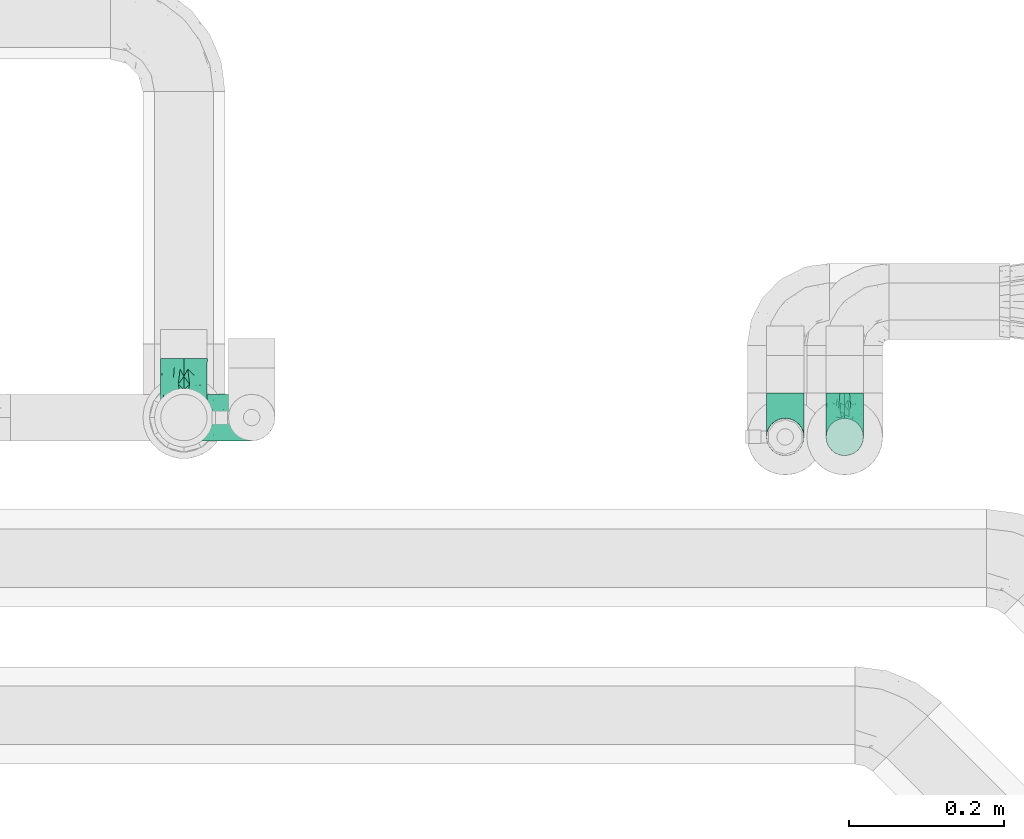
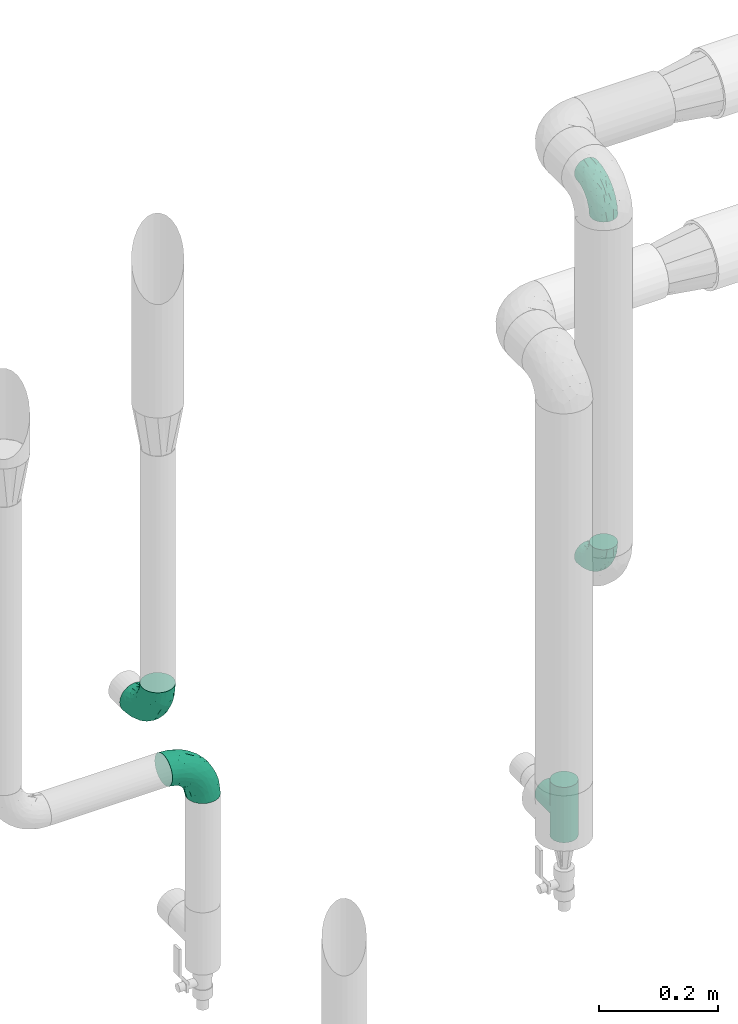
# One storey, part 684 of 827: 5 flow fittings.
"""IFC2X3 building model written with IfcOpenShell, lengths in millimetres."""

from ifc_helpers import new_model, entity, si_unit, converted_unit, derived_unit, direction, frame, origin, place, context, subcontext, project, spatial, faceted_brep, source, transform, mapped, material, type_object, type_shapes, element, save


model = new_model("IFC2X3")

# Units and contexts
model_context = context("Model", 3, precision=0.01, world=origin(), true_north=direction((6.12303176911189e-17, 1.0)))
body_context = subcontext(model_context, "Body", "Model", "MODEL_VIEW")
ifc_project = project(units=[si_unit("LENGTHUNIT", "METRE", prefix="MILLI"), si_unit("AREAUNIT", "SQUARE_METRE"), si_unit("VOLUMEUNIT", "CUBIC_METRE"), converted_unit("PLANEANGLEUNIT", "DEGREE", entity("IfcRatioMeasure", 0.0174532925199433), si_unit("PLANEANGLEUNIT", "RADIAN"), dimensions=[0, 0, 0, 0, 0, 0, 0]), si_unit("MASSUNIT", "GRAM", prefix="KILO"), derived_unit("MASSDENSITYUNIT", [(si_unit("MASSUNIT", "GRAM", prefix="KILO"), 1), (si_unit("LENGTHUNIT", "METRE"), -3)]), derived_unit("MOMENTOFINERTIAUNIT", [(si_unit("LENGTHUNIT", "METRE"), 4)]), si_unit("TIMEUNIT", "SECOND"), si_unit("FREQUENCYUNIT", "HERTZ"), si_unit("THERMODYNAMICTEMPERATUREUNIT", "DEGREE_CELSIUS"), derived_unit("THERMALTRANSMITTANCEUNIT", [(si_unit("MASSUNIT", "GRAM", prefix="KILO"), 1), (si_unit("THERMODYNAMICTEMPERATUREUNIT", "KELVIN"), -1), (si_unit("TIMEUNIT", "SECOND"), -3)]), derived_unit("VOLUMETRICFLOWRATEUNIT", [(si_unit("LENGTHUNIT", "METRE"), 3), (si_unit("TIMEUNIT", "SECOND"), -1)]), derived_unit("MASSFLOWRATEUNIT", [(si_unit("MASSUNIT", "GRAM", prefix="KILO"), 1), (si_unit("TIMEUNIT", "SECOND"), -1)]), derived_unit("ROTATIONALFREQUENCYUNIT", [(si_unit("TIMEUNIT", "SECOND"), -1)]), si_unit("ELECTRICCURRENTUNIT", "AMPERE"), si_unit("ELECTRICVOLTAGEUNIT", "VOLT"), si_unit("POWERUNIT", "WATT"), si_unit("FORCEUNIT", "NEWTON", prefix="KILO"), si_unit("ILLUMINANCEUNIT", "LUX"), si_unit("LUMINOUSFLUXUNIT", "LUMEN"), si_unit("LUMINOUSINTENSITYUNIT", "CANDELA"), derived_unit("USERDEFINED", [(si_unit("MASSUNIT", "GRAM", prefix="KILO"), -1), (si_unit("LENGTHUNIT", "METRE"), -2), (si_unit("TIMEUNIT", "SECOND"), 3), (si_unit("LUMINOUSFLUXUNIT", "LUMEN"), 1)]), derived_unit("LINEARVELOCITYUNIT", [(si_unit("LENGTHUNIT", "METRE"), 1), (si_unit("TIMEUNIT", "SECOND"), -1)]), si_unit("PRESSUREUNIT", "PASCAL"), derived_unit("USERDEFINED", [(si_unit("LENGTHUNIT", "METRE"), -2), (si_unit("MASSUNIT", "GRAM", prefix="KILO"), 1), (si_unit("TIMEUNIT", "SECOND"), -2)]), derived_unit("LINEARFORCEUNIT", [(si_unit("MASSUNIT", "GRAM", prefix="KILO"), 1), (si_unit("LENGTHUNIT", "METRE"), 1), (si_unit("TIMEUNIT", "SECOND"), -2), (si_unit("LENGTHUNIT", "METRE"), -1)]), derived_unit("PLANARFORCEUNIT", [(si_unit("MASSUNIT", "GRAM", prefix="KILO"), 1), (si_unit("LENGTHUNIT", "METRE"), 1), (si_unit("TIMEUNIT", "SECOND"), -2), (si_unit("LENGTHUNIT", "METRE"), -2)])], contexts=[model_context])

# Site, building, storey
site_placement = place(None, origin())
site = spatial("IfcSite", under=ifc_project, at=site_placement, CompositionType="ELEMENT")
building_placement = place(site_placement, origin())
building = spatial("IfcBuilding", under=site, at=building_placement, CompositionType="ELEMENT")
storey_placement = place(building_placement, frame((0.0, 0.0, 28200.0)))
storey = spatial("IfcBuildingStorey", under=building, at=storey_placement, Name="08", CompositionType="ELEMENT", Elevation=28200.0)

# Flow fittings
ifc_material = material()
pipe_fitting_type_1 = type_object("IfcPipeFittingType", Name="ADSK_1", PredefinedType="NOTDEFINED", material=ifc_material)
shared_shape_1 = source(origin(), body_context, "Body", "Brep", [
    faceted_brep([(-57.0, 12.07, -20.91), (-57.0, 6.25, -23.33), (-57.0, 0.0, -24.15), (-57.0, -6.25, -23.33), (-57.0, -12.08, -20.91), (-57.0, -17.08, -17.08), (-57.0, -20.91, -12.08), (-57.0, -23.33, -6.25), (-57.0, -24.15, 0.0), (-57.0, -23.33, 6.25), (-57.0, -20.91, 12.07), (-57.0, -17.08, 17.08), (-57.0, -12.08, 20.91), (-57.0, -6.25, 23.33), (-57.0, 0.0, 24.15), (-57.0, 6.25, 23.33), (-57.0, 12.07, 20.91), (-57.0, 17.08, 17.08), (-57.0, 20.91, 12.07), (-57.0, 23.33, 6.25), (-57.0, 24.15, 0.0), (-57.0, 23.33, -6.25), (-57.0, 20.91, -12.08), (-57.0, 17.08, -17.08), (0.0, 57.0, -24.15), (-6.25, 57.0, -23.33), (-12.07, 57.0, -20.91), (-17.08, 57.0, -17.08), (-20.91, 57.0, -12.08), (-23.33, 57.0, -6.25), (-24.15, 57.0, 0.0), (-23.33, 57.0, 6.25), (-20.91, 57.0, 12.07), (-17.08, 57.0, 17.08), (-12.07, 57.0, 20.91), (-6.25, 57.0, 23.33), (0.0, 57.0, 24.15), (6.25, 57.0, 23.33), (12.08, 57.0, 20.91), (17.08, 57.0, 17.08), (20.91, 57.0, 12.07), (23.33, 57.0, 6.25), (24.15, 57.0, 0.0), (23.33, 57.0, -6.25), (20.91, 57.0, -12.08), (17.08, 57.0, -17.08), (12.08, 57.0, -20.91), (6.25, 57.0, -23.33), (14.9, 21.14, 6.17), (13.61, 24.64, 12.48), (6.23, 8.95, 8.98), (-41.47, -21.06, 0.0), (-41.92, -18.38, 13.72), (-24.64, -13.61, 12.48), (-37.37, -13.24, 18.15), (-6.8, -4.93, 8.18), (-21.76, -15.19, 6.22), (-12.78, -9.18, 0.0), (-37.73, -20.51, 7.75), (-7.38, 7.38, 20.24), (-23.37, -4.26, 20.42), (-11.9, -3.19, 15.86), (-42.14, -8.7, 21.82), (13.24, 37.37, 18.15), (9.33, 23.53, 16.85), (4.26, 23.37, 20.42), (2.77, 10.92, 15.55), (-29.46, 0.91, 23.52), (-44.13, 20.56, 15.69), (-39.25, 26.33, 10.88), (-49.02, 22.92, 9.96), (-34.58, 23.87, 17.15), (-15.8, 6.8, 22.81), (-8.67, 20.47, 23.88), (-18.12, 12.9, 24.08), (-48.29, 14.92, 19.65), (-44.06, -2.85, 23.78), (-9.23, 48.95, 22.58), (-3.78, 42.74, 24.07), (-40.34, 4.26, 24.09), (-44.02, 26.14, 5.46), (-44.04, 9.88, 22.74), (-4.95, 16.87, 22.52), (-2.75, 1.43, 12.5), (-25.48, 40.98, 10.71), (20.51, 37.73, 7.75), (18.38, 41.92, 13.72), (8.7, 42.14, 21.82), (-25.95, -17.97, 0.0), (2.85, 44.06, 23.78), (21.06, 41.47, 0.0), (17.97, 25.95, 0.0), (-24.04, -9.27, 17.13), (-33.26, 33.26, 5.86), (-28.55, 40.57, 0.0), (-40.57, 28.55, 0.0), (-25.29, 47.19, 4.06), (-27.01, 31.1, 16.77), (-15.7, 43.95, 19.9), (-20.27, 45.22, 15.61), (-30.53, 31.98, 12.64), (-11.28, 38.33, 22.92), (-9.97, 27.88, 24.09), (-20.15, 30.26, 21.25), (-31.25, 11.75, 23.64), (-28.75, 7.23, 24.15), (-29.53, 18.06, 22.27), (-28.44, 24.21, 20.02), (-37.55, 17.7, 20.26), (-15.88, 29.25, 22.99), (-20.82, 20.82, 23.44), (-0.91, 29.46, 23.52), (-13.5, -7.67, 12.04), (1.49, 1.56, 5.16), (8.86, 10.35, 4.59), (0.38, -0.38, 0.0), (9.18, 12.78, 0.0), (-37.37, -13.24, -18.15), (8.86, 10.35, -4.59), (-45.22, 20.27, -15.61), (-43.95, 15.7, -19.9), (-38.33, 11.28, -22.92), (-48.95, 9.23, -22.58), (-47.19, 25.29, -4.06), (-33.26, 33.26, -5.86), (18.38, 41.92, -13.72), (-30.26, 20.15, -21.25), (2.85, 44.06, -23.78), (-4.26, 40.34, -24.09), (-40.98, 25.48, -10.71), (-41.92, -18.38, -13.72), (9.25, 23.5, -16.92), (4.26, 23.37, -20.42), (13.24, 37.37, -18.15), (-37.73, -20.51, -7.75), (-11.75, 31.25, -23.64), (-7.23, 28.75, -24.15), (-12.9, 18.12, -24.08), (8.7, 42.14, -21.82), (-44.06, -2.85, -23.78), (-6.8, 15.8, -22.81), (-20.47, 8.67, -23.88), (-24.64, -13.61, -12.48), (-42.74, 3.78, -24.07), (-18.06, 29.53, -22.27), (-24.21, 28.44, -20.02), (-27.88, 9.97, -24.09), (-31.1, 27.01, -16.77), (-26.14, 44.02, -5.46), (14.9, 21.14, -6.17), (20.51, 37.73, -7.75), (-9.88, 44.04, -22.74), (-20.56, 44.13, -15.69), (-21.76, -15.19, -6.22), (-13.5, -7.67, -12.04), (-24.14, -9.76, -16.74), (-11.9, -3.19, -15.86), (-14.92, 48.29, -19.65), (-23.37, -4.26, -20.42), (-0.91, 29.46, -23.52), (-26.33, 39.25, -10.88), (-23.87, 34.58, -17.15), (-42.14, -8.7, -21.82), (-22.92, 49.02, -9.96), (13.61, 24.64, -12.48), (-31.98, 30.53, -12.64), (-16.87, 4.95, -22.52), (-17.7, 37.55, -20.26), (-29.25, 15.88, -22.99), (-20.82, 20.82, -23.44), (-29.46, 0.91, -23.52), (-7.38, 7.38, -20.24), (2.77, 10.92, -15.55), (6.23, 8.95, -8.98), (-6.8, -4.93, -8.18), (-2.81, 1.41, -12.54), (1.49, 1.56, -5.16)], [[[0, 1, 2, 3, 4, 5, 6, 7, 8, 9, 10, 11, 12, 13, 14, 15, 16, 17, 18, 19, 20, 21, 22, 23]], [[24, 25, 26, 27, 28, 29, 30, 31, 32, 33, 34, 35, 36, 37, 38, 39, 40, 41, 42, 43, 44, 45, 46, 47]], [[48, 49, 50]], [[9, 8, 51]], [[52, 53, 54]], [[55, 56, 57]], [[10, 58, 52]], [[9, 58, 10]], [[59, 60, 61]], [[54, 12, 11]], [[54, 62, 12]], [[63, 39, 38]], [[64, 65, 66]], [[62, 60, 67]], [[68, 69, 70]], [[71, 69, 68]], [[72, 73, 74]], [[16, 75, 17]], [[13, 76, 14]], [[35, 77, 78]], [[14, 79, 15]], [[17, 68, 18]], [[14, 76, 79]], [[20, 19, 80]], [[70, 19, 18]], [[81, 15, 79]], [[15, 81, 16]], [[73, 72, 82]], [[66, 83, 50]], [[32, 31, 84]], [[85, 86, 49]], [[63, 87, 65]], [[56, 58, 88]], [[36, 89, 37]], [[85, 41, 40]], [[36, 35, 78]], [[90, 41, 85]], [[40, 39, 86]], [[12, 62, 13]], [[86, 85, 40]], [[48, 85, 49]], [[85, 91, 90]], [[87, 38, 37]], [[92, 60, 54]], [[80, 69, 93]], [[93, 94, 95]], [[10, 52, 11]], [[94, 96, 30]], [[97, 98, 99]], [[80, 93, 95]], [[100, 97, 84]], [[99, 98, 33]], [[101, 102, 78]], [[103, 101, 98]], [[96, 31, 30]], [[77, 98, 101]], [[77, 35, 34]], [[34, 33, 98]], [[9, 51, 58]], [[87, 63, 38]], [[104, 105, 74]], [[106, 103, 107]], [[106, 81, 104]], [[75, 68, 17]], [[108, 107, 71]], [[33, 32, 99]], [[109, 103, 110]], [[101, 109, 102]], [[89, 78, 111]], [[53, 52, 58]], [[54, 11, 52]], [[60, 62, 54]], [[88, 58, 51]], [[76, 62, 67]], [[53, 112, 92]], [[60, 59, 72]], [[39, 63, 86]], [[49, 86, 63]], [[89, 87, 37]], [[42, 41, 90]], [[111, 82, 65]], [[111, 65, 87]], [[65, 59, 66]], [[104, 81, 79]], [[75, 81, 108]], [[32, 84, 99]], [[97, 99, 84]], [[98, 97, 103]], [[106, 107, 108]], [[74, 102, 110]], [[111, 78, 102]], [[74, 110, 104]], [[74, 67, 72]], [[61, 92, 112]], [[66, 59, 61]], [[56, 53, 58]], [[66, 50, 49]], [[61, 112, 83]], [[66, 49, 64]], [[78, 89, 36]], [[87, 89, 111]], [[62, 76, 13]], [[79, 76, 67]], [[100, 93, 69]], [[96, 93, 84]], [[55, 113, 50]], [[113, 114, 50]], [[104, 79, 105]], [[106, 104, 110]], [[20, 80, 95]], [[85, 48, 91]], [[115, 114, 113]], [[116, 91, 48]], [[70, 80, 19]], [[93, 96, 94]], [[84, 31, 96]], [[103, 106, 110]], [[81, 106, 108]], [[103, 97, 107]], [[71, 107, 97]], [[71, 97, 100]], [[108, 71, 68]], [[79, 67, 105]], [[67, 74, 105]], [[115, 113, 57]], [[112, 56, 55]], [[56, 88, 57]], [[60, 72, 67]], [[82, 72, 59]], [[65, 82, 59]], [[82, 111, 73]], [[111, 102, 73]], [[102, 74, 73]], [[81, 75, 16]], [[68, 75, 108]], [[68, 70, 18]], [[80, 70, 69]], [[98, 77, 34]], [[78, 77, 101]], [[93, 100, 84]], [[71, 100, 69]], [[102, 109, 110]], [[101, 103, 109]], [[53, 92, 54]], [[61, 60, 92]], [[56, 112, 53]], [[83, 112, 55]], [[50, 83, 55]], [[61, 83, 66]], [[49, 63, 64]], [[65, 64, 63]], [[57, 113, 55]], [[114, 115, 116]], [[116, 48, 114]], [[48, 50, 114]], [[117, 5, 4]], [[116, 115, 118]], [[119, 120, 23]], [[121, 122, 120]], [[95, 123, 20]], [[0, 23, 120]], [[124, 95, 94]], [[125, 45, 44]], [[121, 120, 126]], [[24, 127, 128]], [[22, 21, 129]], [[0, 122, 1]], [[5, 117, 130]], [[131, 132, 133]], [[134, 88, 51]], [[135, 136, 137]], [[6, 5, 130]], [[46, 138, 47]], [[139, 3, 2]], [[140, 141, 137]], [[6, 134, 7]], [[134, 130, 142]], [[143, 2, 1]], [[144, 126, 145]], [[121, 146, 143]], [[147, 120, 119]], [[94, 148, 124]], [[149, 150, 91]], [[30, 29, 148]], [[151, 25, 128]], [[27, 152, 28]], [[134, 153, 88]], [[154, 155, 156]], [[27, 26, 157]], [[151, 26, 25]], [[155, 158, 156]], [[24, 47, 127]], [[1, 122, 143]], [[138, 132, 159]], [[160, 152, 161]], [[24, 128, 25]], [[46, 133, 138]], [[162, 117, 4]], [[148, 160, 124]], [[152, 160, 163]], [[154, 142, 155]], [[45, 125, 133]], [[133, 46, 45]], [[125, 164, 133]], [[51, 7, 134]], [[42, 90, 43]], [[165, 147, 129]], [[153, 134, 142]], [[43, 150, 44]], [[162, 4, 3]], [[141, 140, 166]], [[117, 162, 158]], [[163, 29, 28]], [[43, 90, 150]], [[123, 21, 20]], [[144, 151, 135]], [[157, 152, 27]], [[167, 145, 161]], [[23, 22, 119]], [[168, 126, 169]], [[121, 168, 146]], [[139, 143, 170]], [[142, 130, 117]], [[8, 7, 51]], [[134, 6, 130]], [[139, 162, 3]], [[170, 166, 158]], [[170, 158, 162]], [[158, 171, 156]], [[44, 150, 125]], [[91, 150, 90]], [[164, 125, 150]], [[132, 138, 133]], [[127, 138, 159]], [[131, 164, 172]], [[132, 171, 140]], [[135, 151, 128]], [[157, 151, 167]], [[22, 129, 119]], [[147, 119, 129]], [[120, 147, 126]], [[144, 145, 167]], [[137, 146, 169]], [[170, 143, 146]], [[137, 169, 135]], [[137, 159, 140]], [[171, 172, 156]], [[173, 174, 175]], [[156, 175, 154]], [[174, 57, 153]], [[132, 172, 171]], [[172, 164, 173]], [[143, 139, 2]], [[162, 139, 170]], [[138, 127, 47]], [[128, 127, 159]], [[165, 124, 160]], [[123, 124, 129]], [[149, 173, 164]], [[176, 174, 173]], [[135, 128, 136]], [[144, 135, 169]], [[150, 149, 164]], [[176, 118, 115]], [[149, 91, 116]], [[30, 148, 94]], [[163, 148, 29]], [[124, 123, 95]], [[129, 21, 123]], [[126, 144, 169]], [[151, 144, 167]], [[126, 147, 145]], [[161, 145, 147]], [[161, 147, 165]], [[167, 161, 152]], [[128, 159, 136]], [[159, 137, 136]], [[154, 153, 142]], [[132, 140, 159]], [[174, 176, 57]], [[57, 88, 153]], [[166, 140, 171]], [[158, 166, 171]], [[166, 170, 141]], [[170, 146, 141]], [[146, 137, 141]], [[151, 157, 26]], [[152, 157, 167]], [[152, 163, 28]], [[148, 163, 160]], [[120, 122, 0]], [[143, 122, 121]], [[124, 165, 129]], [[161, 165, 160]], [[146, 168, 169]], [[121, 126, 168]], [[142, 117, 155]], [[158, 155, 117]], [[175, 156, 172]], [[153, 154, 174]], [[173, 175, 172]], [[174, 154, 175]], [[164, 131, 133]], [[172, 132, 131]], [[176, 173, 118]], [[57, 176, 115]], [[173, 149, 118]], [[149, 116, 118]]]),
])
type_shapes(pipe_fitting_type_1, [shared_shape_1])
for number, where, z_axis, x_axis, name in (
    (1, (47661.17, 18966.22, 1650.0), (1.0, 0.0, 0.0), (0.0, -1.0, 0.0), "ADSK_1"),
    (2, (47661.17, 18966.22, 861.88), (1.0, 0.0, 0.0), (0.0, 0.0, -1.0), "ADSK_1"),
):
    element("IfcFlowFitting", number, at=place(storey_placement, frame(where, z_axis=z_axis, x_axis=x_axis)), inside=storey, type_object=pipe_fitting_type_1, material=ifc_material, Name=name, ObjectType="ADSK_1", context=body_context, shape_type="MappedRepresentation", body=[
        mapped(shared_shape_1, transform((0.0, 0.0, 0.0), scale=1.0)),
    ])
pipe_fitting_type_2 = type_object("IfcPipeFittingType", Name="ADSK_1", PredefinedType="NOTDEFINED", material=ifc_material)
shared_shape_2 = source(origin(), body_context, "Body", "Brep", [
    faceted_brep([(-76.0, 15.07, -26.11), (-76.0, 7.8, -29.12), (-76.0, 0.0, -30.15), (-76.0, -7.8, -29.12), (-76.0, -15.08, -26.11), (-76.0, -21.32, -21.32), (-76.0, -26.11, -15.08), (-76.0, -29.12, -7.8), (-76.0, -30.15, 0.0), (-76.0, -29.12, 7.8), (-76.0, -26.11, 15.07), (-76.0, -21.32, 21.32), (-76.0, -15.08, 26.11), (-76.0, -7.8, 29.12), (-76.0, 0.0, 30.15), (-76.0, 7.8, 29.12), (-76.0, 15.07, 26.11), (-76.0, 21.32, 21.32), (-76.0, 26.11, 15.07), (-76.0, 29.12, 7.8), (-76.0, 30.15, 0.0), (-76.0, 29.12, -7.8), (-76.0, 26.11, -15.08), (-76.0, 21.32, -21.32), (0.0, 76.0, -30.15), (-7.8, 76.0, -29.12), (-15.07, 76.0, -26.11), (-21.32, 76.0, -21.32), (-26.11, 76.0, -15.08), (-29.12, 76.0, -7.8), (-30.15, 76.0, 0.0), (-29.12, 76.0, 7.8), (-26.11, 76.0, 15.07), (-21.32, 76.0, 21.32), (-15.07, 76.0, 26.11), (-7.8, 76.0, 29.12), (0.0, 76.0, 30.15), (7.8, 76.0, 29.12), (15.08, 76.0, 26.11), (21.32, 76.0, 21.32), (26.11, 76.0, 15.07), (29.12, 76.0, 7.8), (30.15, 76.0, 0.0), (29.12, 76.0, -7.8), (26.11, 76.0, -15.08), (21.32, 76.0, -21.32), (15.08, 76.0, -26.11), (7.8, 76.0, -29.12), (10.79, 31.43, 21.07), (4.32, 31.7, 25.72), (1.65, 15.19, 19.92), (-61.17, -27.8, 0.0), (-51.1, -25.49, 9.84), (-56.14, -10.61, 27.27), (-31.7, -4.32, 25.72), (-39.75, 1.72, 29.41), (-43.2, -24.95, 0.0), (-1.86, 1.86, 0.0), (4.49, 7.65, 5.78), (-7.82, -4.61, 5.83), (-56.21, -22.79, 17.21), (-58.98, -3.38, 29.7), (-53.96, 5.6, 30.07), (-10.86, 10.86, 25.48), (-17.2, -2.6, 20.44), (-49.15, -16.01, 22.7), (-22.18, -14.24, 7.99), (-28.4, -17.42, 0.0), (-13.61, -9.88, 0.0), (-39.0, 23.48, 27.76), (-58.76, 12.54, 28.36), (-41.61, 15.41, 29.48), (16.01, 49.15, 22.7), (-58.55, 25.93, 19.53), (-51.53, 33.5, 13.51), (-64.92, 28.76, 12.4), (-7.48, 23.14, 28.25), (-1.72, 39.75, 29.41), (-12.04, 27.88, 29.88), (-63.91, 18.81, 24.52), (-11.63, 65.16, 28.18), (-4.97, 57.02, 30.05), (9.88, 13.61, 0.0), (-62.5, 31.74, 5.02), (-45.17, 30.98, 21.2), (-21.78, 9.76, 28.58), (10.61, 56.14, 27.27), (-32.09, 54.42, 13.26), (22.79, 56.21, 17.21), (15.38, 31.17, 15.63), (25.49, 51.1, 9.84), (21.84, 36.35, 5.92), (24.95, 43.2, 0.0), (3.38, 58.98, 29.7), (-31.17, -15.38, 15.63), (-39.39, 41.78, 15.45), (-34.56, 41.13, 20.79), (-39.81, -23.25, 5.49), (27.8, 61.17, 0.0), (-31.74, 62.5, 5.02), (-53.07, 36.29, 0.0), (-42.95, 42.95, 7.29), (-36.29, 53.07, 0.0), (-19.83, 58.51, 24.79), (-25.48, 60.2, 19.41), (-14.53, 50.96, 28.57), (-13.31, 37.09, 30.07), (-26.16, 40.06, 26.4), (-32.43, -10.35, 21.9), (17.42, 28.4, 0.0), (14.24, 22.18, 7.99), (-38.67, 9.72, 30.15), (-24.66, 17.36, 30.09), (-37.08, 31.49, 24.99), (-49.27, 22.83, 25.24), (-20.8, 38.81, 28.63), (-27.58, 27.58, 29.2), (-36.07, -20.23, 10.71), (-15.19, -6.16, 14.9), (6.6, 15.4, 14.49), (-2.51, 2.51, 11.35), (-65.16, 11.63, -28.18), (-49.15, -16.01, -22.7), (-57.02, 4.97, -30.05), (-25.93, 58.55, -19.53), (-33.5, 51.53, -13.51), (-28.76, 64.92, -12.4), (-60.2, 25.48, -19.41), (-58.51, 19.83, -24.79), (4.61, 7.82, -5.83), (-7.65, -4.49, -5.78), (-2.51, 2.51, -11.35), (-62.5, 31.74, -5.02), (-50.96, 14.53, -28.57), (-37.09, 13.31, -30.07), (-42.95, 42.95, -7.29), (25.49, 51.1, -9.84), (22.79, 56.21, -17.21), (-40.06, 26.16, -26.4), (3.38, 58.98, -29.7), (-5.6, 53.96, -30.07), (-27.88, 12.04, -29.88), (-9.76, 21.78, -28.58), (-23.14, 7.48, -28.25), (-51.1, -25.49, -9.84), (15.38, 31.17, -15.63), (16.01, 49.15, -22.7), (-23.48, 39.0, -27.76), (-12.54, 58.76, -28.36), (-15.41, 41.61, -29.48), (-56.21, -22.79, -17.21), (-9.72, 38.67, -30.15), (-17.36, 24.66, -30.09), (-22.18, -14.24, -7.99), (-41.13, 34.56, -20.79), (-31.74, 62.5, -5.02), (-58.98, -3.38, -29.7), (-31.17, -15.38, -15.63), (-56.14, -10.61, -27.27), (14.24, 22.18, -7.99), (23.25, 39.81, -5.49), (-31.49, 37.08, -24.99), (-15.19, -6.16, -14.9), (1.65, 15.19, -19.92), (-18.81, 63.91, -24.52), (-32.59, -11.62, -20.84), (-31.7, -4.32, -25.72), (-17.2, -2.6, -20.44), (-39.75, 1.72, -29.41), (-54.42, 32.09, -13.26), (-30.98, 45.17, -21.2), (10.61, 56.14, -27.27), (10.23, 31.31, -21.52), (4.32, 31.7, -25.72), (-41.78, 39.39, -15.45), (-1.72, 39.75, -29.41), (-36.35, -21.84, -5.92), (-22.83, 49.27, -25.24), (-38.81, 20.8, -28.63), (-27.58, 27.58, -29.2), (-10.86, 10.86, -25.48), (20.23, 36.07, -10.71), (6.6, 15.4, -14.49)], [[[0, 1, 2, 3, 4, 5, 6, 7, 8, 9, 10, 11, 12, 13, 14, 15, 16, 17, 18, 19, 20, 21, 22, 23]], [[24, 25, 26, 27, 28, 29, 30, 31, 32, 33, 34, 35, 36, 37, 38, 39, 40, 41, 42, 43, 44, 45, 46, 47]], [[48, 49, 50]], [[51, 52, 9]], [[53, 54, 55]], [[9, 52, 10]], [[56, 52, 51]], [[57, 58, 59]], [[11, 10, 60]], [[14, 61, 62]], [[63, 54, 64]], [[65, 12, 11]], [[65, 53, 12]], [[66, 67, 68]], [[69, 70, 71]], [[72, 39, 38]], [[73, 74, 75]], [[15, 70, 16]], [[76, 77, 78]], [[16, 79, 17]], [[13, 61, 14]], [[35, 80, 81]], [[14, 62, 15]], [[17, 73, 18]], [[57, 82, 58]], [[20, 19, 83]], [[75, 19, 18]], [[70, 15, 62]], [[73, 84, 74]], [[78, 85, 76]], [[38, 86, 72]], [[32, 31, 87]], [[88, 89, 90]], [[91, 92, 90]], [[72, 86, 49]], [[36, 93, 37]], [[75, 83, 19]], [[36, 35, 81]], [[60, 94, 65]], [[40, 90, 41]], [[95, 96, 87]], [[88, 90, 40]], [[66, 97, 67]], [[90, 98, 41]], [[40, 39, 88]], [[99, 31, 30]], [[20, 83, 100]], [[101, 102, 100]], [[52, 60, 10]], [[102, 99, 30]], [[96, 103, 104]], [[83, 101, 100]], [[12, 53, 13]], [[104, 103, 33]], [[105, 106, 81]], [[107, 105, 103]], [[64, 54, 108]], [[80, 103, 105]], [[80, 35, 34]], [[34, 33, 103]], [[86, 38, 37]], [[109, 110, 82]], [[71, 111, 112]], [[69, 107, 113]], [[79, 73, 17]], [[114, 113, 84]], [[33, 32, 104]], [[115, 107, 116]], [[105, 115, 106]], [[93, 81, 77]], [[54, 53, 65]], [[61, 53, 55]], [[108, 94, 64]], [[54, 63, 85]], [[93, 86, 37]], [[77, 76, 49]], [[77, 49, 86]], [[49, 63, 50]], [[60, 52, 117]], [[65, 11, 60]], [[39, 72, 88]], [[89, 88, 72]], [[71, 70, 62]], [[79, 70, 114]], [[103, 96, 107]], [[69, 113, 114]], [[112, 106, 116]], [[77, 81, 106]], [[112, 116, 71]], [[112, 55, 85]], [[64, 50, 63]], [[57, 59, 68]], [[32, 87, 104]], [[96, 104, 87]], [[94, 118, 64]], [[50, 119, 89]], [[50, 64, 118]], [[50, 89, 48]], [[81, 93, 36]], [[86, 93, 77]], [[53, 61, 13]], [[62, 61, 55]], [[71, 62, 111]], [[69, 71, 116]], [[95, 101, 74]], [[99, 101, 87]], [[118, 66, 59]], [[117, 97, 66]], [[117, 66, 94]], [[91, 89, 110]], [[91, 110, 109]], [[110, 89, 119]], [[9, 8, 51]], [[98, 90, 92]], [[98, 42, 41]], [[101, 83, 74]], [[101, 99, 102]], [[87, 31, 99]], [[62, 55, 111]], [[55, 112, 111]], [[107, 69, 116]], [[70, 69, 114]], [[107, 96, 113]], [[84, 113, 96]], [[84, 96, 95]], [[114, 84, 73]], [[70, 79, 16]], [[73, 79, 114]], [[54, 85, 55]], [[76, 85, 63]], [[49, 76, 63]], [[77, 106, 78]], [[106, 112, 78]], [[85, 78, 112]], [[73, 75, 18]], [[83, 75, 74]], [[103, 80, 34]], [[81, 80, 105]], [[101, 95, 87]], [[84, 95, 74]], [[106, 115, 116]], [[105, 107, 115]], [[120, 59, 58]], [[82, 110, 58]], [[119, 58, 110]], [[118, 59, 120]], [[66, 68, 59]], [[54, 65, 108]], [[94, 108, 65]], [[66, 118, 94]], [[50, 118, 120]], [[50, 120, 119]], [[119, 120, 58]], [[89, 72, 48]], [[49, 48, 72]], [[60, 117, 94]], [[117, 52, 97]], [[52, 56, 97]], [[67, 97, 56]], [[92, 91, 109]], [[89, 91, 90]], [[121, 1, 0]], [[122, 5, 4]], [[2, 1, 123]], [[124, 125, 126]], [[127, 128, 23]], [[129, 130, 131]], [[100, 132, 20]], [[133, 134, 123]], [[135, 100, 102]], [[136, 137, 44]], [[133, 128, 138]], [[24, 139, 140]], [[141, 142, 143]], [[121, 128, 133]], [[6, 144, 7]], [[137, 145, 146]], [[144, 51, 7]], [[147, 148, 149]], [[144, 6, 150]], [[149, 151, 152]], [[153, 68, 67]], [[154, 128, 127]], [[30, 155, 102]], [[43, 42, 98]], [[156, 3, 2]], [[157, 144, 150]], [[158, 4, 3]], [[24, 140, 25]], [[155, 135, 102]], [[159, 160, 109]], [[30, 29, 155]], [[147, 138, 161]], [[27, 124, 28]], [[57, 129, 82]], [[162, 163, 131]], [[27, 26, 164]], [[148, 26, 25]], [[165, 166, 167]], [[24, 47, 139]], [[143, 168, 141]], [[22, 21, 169]], [[125, 124, 170]], [[148, 25, 140]], [[46, 146, 171]], [[158, 122, 4]], [[0, 23, 128]], [[1, 121, 123]], [[109, 82, 159]], [[45, 44, 137]], [[146, 46, 45]], [[136, 43, 98]], [[132, 21, 20]], [[136, 98, 92]], [[172, 173, 146]], [[46, 171, 47]], [[43, 136, 44]], [[174, 154, 169]], [[171, 173, 175]], [[6, 5, 150]], [[126, 29, 28]], [[176, 56, 144]], [[122, 158, 166]], [[164, 124, 27]], [[177, 161, 170]], [[23, 22, 127]], [[178, 138, 179]], [[133, 178, 134]], [[156, 123, 168]], [[156, 158, 3]], [[168, 143, 166]], [[168, 166, 158]], [[166, 180, 167]], [[173, 171, 146]], [[139, 171, 175]], [[172, 145, 163]], [[173, 180, 142]], [[5, 122, 150]], [[157, 150, 122]], [[137, 136, 181]], [[146, 45, 137]], [[149, 148, 140]], [[164, 148, 177]], [[128, 154, 138]], [[147, 161, 177]], [[152, 134, 179]], [[168, 123, 134]], [[152, 179, 149]], [[152, 175, 142]], [[57, 130, 129]], [[157, 165, 167]], [[22, 169, 127]], [[154, 127, 169]], [[163, 167, 180]], [[162, 157, 167]], [[173, 163, 180]], [[182, 163, 145]], [[123, 156, 2]], [[158, 156, 168]], [[171, 139, 47]], [[140, 139, 175]], [[149, 140, 151]], [[147, 149, 179]], [[174, 135, 125]], [[132, 135, 169]], [[176, 157, 153]], [[176, 153, 67]], [[153, 157, 162]], [[182, 159, 129]], [[181, 160, 159]], [[181, 159, 145]], [[51, 144, 56]], [[51, 8, 7]], [[135, 132, 100]], [[169, 21, 132]], [[126, 155, 29]], [[135, 155, 125]], [[140, 175, 151]], [[175, 152, 151]], [[138, 147, 179]], [[148, 147, 177]], [[138, 154, 161]], [[170, 161, 154]], [[170, 154, 174]], [[177, 170, 124]], [[148, 164, 26]], [[124, 164, 177]], [[173, 142, 175]], [[143, 142, 180]], [[166, 143, 180]], [[168, 134, 141]], [[134, 152, 141]], [[142, 141, 152]], [[124, 126, 28]], [[155, 126, 125]], [[128, 121, 0]], [[123, 121, 133]], [[135, 174, 169]], [[170, 174, 125]], [[134, 178, 179]], [[133, 138, 178]], [[130, 153, 162]], [[68, 153, 130]], [[57, 68, 130]], [[182, 129, 131]], [[159, 82, 129]], [[157, 122, 165]], [[166, 165, 122]], [[163, 162, 167]], [[162, 131, 130]], [[145, 172, 146]], [[163, 173, 172]], [[159, 182, 145]], [[131, 163, 182]], [[56, 176, 67]], [[157, 176, 144]], [[137, 181, 145]], [[181, 136, 160]], [[136, 92, 160]], [[109, 160, 92]]]),
])
type_shapes(pipe_fitting_type_2, [shared_shape_2])
for number, where, z_axis, x_axis, name in (
    (3, (46807.82, 18991.22, 836.38), (1.0, 0.0, 0.0), (0.0, 0.0, -1.0), "ADSK_1"),
    (4, (46895.32, 18991.22, 730.0), (0.0, 1.0, 0.0), (1.0, 0.0, 0.0), "ADSK_1"),
):
    element("IfcFlowFitting", number, at=place(storey_placement, frame(where, z_axis=z_axis, x_axis=x_axis)), inside=storey, type_object=pipe_fitting_type_2, material=ifc_material, Name=name, ObjectType="ADSK_1", context=body_context, shape_type="MappedRepresentation", body=[
        mapped(shared_shape_2, transform((0.0, 0.0, 0.0), scale=1.0)),
    ])
pipe_fitting_type_3 = type_object("IfcPipeFittingType", Name="ADSK_1", PredefinedType="NOTDEFINED", material=ifc_material)
shared_shape_3 = source(origin(), body_context, "Body", "Brep", [
    faceted_brep([(-57.0, 12.07, -20.91), (-57.0, 6.25, -23.33), (-57.0, 0.0, -24.15), (-57.0, -6.25, -23.33), (-57.0, -12.08, -20.91), (-57.0, -17.08, -17.08), (-57.0, -20.91, -12.08), (-57.0, -23.33, -6.25), (-57.0, -24.15, 0.0), (-57.0, -23.33, 6.25), (-57.0, -20.91, 12.07), (-57.0, -17.08, 17.08), (-57.0, -12.08, 20.91), (-57.0, -6.25, 23.33), (-57.0, 0.0, 24.15), (-57.0, 6.25, 23.33), (-57.0, 12.07, 20.91), (-57.0, 17.08, 17.08), (-57.0, 20.91, 12.07), (-57.0, 23.33, 6.25), (-57.0, 24.15, 0.0), (-57.0, 23.33, -6.25), (-57.0, 20.91, -12.08), (-57.0, 17.08, -17.08), (57.0, 0.0, -24.15), (57.0, 6.25, -23.33), (57.0, 12.07, -20.91), (57.0, 17.08, -17.08), (57.0, 20.91, -12.08), (57.0, 23.33, -6.25), (57.0, 24.15, 0.0), (57.0, 23.33, 6.25), (57.0, 20.91, 12.07), (57.0, 17.08, 17.08), (57.0, 12.07, 20.91), (57.0, 6.25, 23.33), (57.0, 0.0, 24.15), (57.0, -6.25, 23.33), (57.0, -12.08, 20.91), (57.0, -17.08, 17.08), (57.0, -20.91, 12.07), (57.0, -23.33, 6.25), (57.0, -24.15, 0.0), (57.0, -23.33, -6.25), (57.0, -20.91, -12.08), (57.0, -17.08, -17.08), (57.0, -12.08, -20.91), (57.0, -6.25, -23.33), (23.27, -23.27, 6.45), (24.15, -24.15, 0.0), (-24.15, -24.15, 0.0), (20.9, -20.9, 12.1), (13.54, -13.54, 20.0), (17.52, -17.52, 16.62), (-23.27, -23.27, 6.45), (-20.9, -20.9, 12.1), (-17.52, -17.52, 16.62), (-13.54, -13.54, 20.0), (-9.19, -9.19, 22.33), (9.19, -9.19, 22.33), (4.64, -4.64, 23.7), (0.0, 0.0, 24.15), (-4.64, -4.64, 23.7), (4.64, -4.64, -23.7), (0.0, 0.0, -24.15), (-4.64, -4.64, -23.7), (-9.19, -9.19, -22.33), (9.19, -9.19, -22.33), (13.54, -13.54, -20.0), (17.52, -17.52, -16.62), (20.9, -20.9, -12.1), (23.27, -23.27, -6.45), (-13.54, -13.54, -20.0), (-17.52, -17.52, -16.62), (-23.27, -23.27, -6.45), (-20.9, -20.9, -12.1), (0.0, -57.0, -24.15), (6.25, -57.0, -23.33), (12.08, -57.0, -20.91), (17.08, -57.0, -17.08), (20.91, -57.0, -12.08), (23.33, -57.0, -6.25), (24.15, -57.0, 0.0), (23.33, -57.0, 6.25), (20.91, -57.0, 12.07), (17.08, -57.0, 17.08), (12.08, -57.0, 20.91), (6.25, -57.0, 23.33), (0.0, -57.0, 24.15), (-6.25, -57.0, 23.33), (-12.07, -57.0, 20.91), (-17.08, -57.0, 17.08), (-20.91, -57.0, 12.07), (-23.33, -57.0, 6.25), (-24.15, -57.0, 0.0), (-23.33, -57.0, -6.25), (-20.91, -57.0, -12.08), (-17.08, -57.0, -17.08), (-12.07, -57.0, -20.91), (-6.25, -57.0, -23.33)], [[[0, 1, 2, 3, 4, 5, 6, 7, 8, 9, 10, 11, 12, 13, 14, 15, 16, 17, 18, 19, 20, 21, 22, 23]], [[24, 25, 26, 27, 28, 29, 30, 31, 32, 33, 34, 35, 36, 37, 38, 39, 40, 41, 42, 43, 44, 45, 46, 47]], [[41, 40, 48]], [[42, 41, 49]], [[50, 9, 8]], [[49, 41, 48]], [[40, 51, 48]], [[39, 38, 52]], [[51, 40, 53]], [[52, 53, 39]], [[53, 40, 39]], [[50, 54, 9]], [[9, 54, 10]], [[54, 55, 10]], [[56, 57, 11]], [[11, 10, 56]], [[11, 57, 12]], [[56, 10, 55]], [[12, 57, 58]], [[52, 38, 59]], [[60, 36, 61]], [[62, 61, 14]], [[59, 37, 60]], [[37, 59, 38]], [[60, 37, 36]], [[61, 36, 35, 15, 14]], [[32, 31, 19, 18]], [[17, 16, 34, 33]], [[18, 17, 33, 32]], [[35, 34, 16, 15]], [[20, 19, 31, 30]], [[62, 13, 58]], [[13, 62, 14]], [[58, 13, 12]], [[27, 23, 22, 28]], [[22, 21, 29, 28]], [[0, 23, 27, 26]], [[20, 30, 29, 21]], [[24, 47, 63]], [[24, 64, 2, 1, 25]], [[64, 24, 63]], [[2, 64, 65]], [[26, 25, 1, 0]], [[65, 66, 3]], [[2, 65, 3]], [[66, 4, 3]], [[63, 47, 67]], [[46, 45, 68]], [[69, 68, 45]], [[44, 70, 69]], [[69, 45, 44]], [[46, 68, 67]], [[43, 42, 49]], [[7, 50, 8]], [[43, 71, 44]], [[71, 43, 49]], [[44, 71, 70]], [[72, 4, 66]], [[72, 5, 4]], [[5, 72, 73]], [[5, 73, 6]], [[74, 50, 7]], [[75, 74, 6]], [[74, 7, 6]], [[75, 6, 73]], [[46, 67, 47]], [[76, 77, 78, 79, 80, 81, 82, 83, 84, 85, 86, 87, 88, 89, 90, 91, 92, 93, 94, 95, 96, 97, 98, 99]], [[50, 94, 93]], [[54, 50, 93]], [[91, 90, 57]], [[56, 92, 91]], [[54, 93, 92]], [[58, 90, 89]], [[55, 54, 92]], [[56, 55, 92]], [[58, 57, 90]], [[88, 61, 62]], [[58, 89, 62]], [[56, 91, 57]], [[62, 89, 88]], [[60, 88, 87]], [[86, 59, 87]], [[84, 83, 48]], [[53, 85, 84]], [[52, 86, 85]], [[49, 83, 82]], [[59, 60, 87]], [[52, 59, 86]], [[49, 48, 83]], [[51, 53, 84]], [[48, 51, 84]], [[52, 85, 53]], [[88, 60, 61]], [[82, 81, 49]], [[71, 49, 81]], [[69, 80, 79]], [[79, 78, 68]], [[71, 81, 80]], [[67, 78, 77]], [[70, 71, 80]], [[69, 70, 80]], [[67, 68, 78]], [[76, 64, 63]], [[67, 77, 63]], [[69, 79, 68]], [[63, 77, 76]], [[65, 76, 99]], [[98, 66, 99]], [[96, 95, 74]], [[73, 97, 96]], [[72, 98, 97]], [[50, 95, 94]], [[66, 65, 99]], [[72, 66, 98]], [[50, 74, 95]], [[75, 73, 96]], [[74, 75, 96]], [[72, 97, 73]], [[76, 65, 64]]]),
])
type_shapes(pipe_fitting_type_3, [shared_shape_3])
flow_fitting_placement = place(storey_placement, frame((47584.3, 18966.22, 400.0), z_axis=(-1.0, 0.0, 0.0), x_axis=(0.0, 0.0, -1.0)))
element("IfcFlowFitting", 5, at=flow_fitting_placement, inside=storey, type_object=pipe_fitting_type_3, material=ifc_material, Name="ADSK_1", ObjectType="ADSK_1", context=body_context, shape_type="MappedRepresentation", body=[
    mapped(shared_shape_3, transform((0.0, 0.0, 0.0), scale=1.0)),
])

save(model, "model.ifc")
